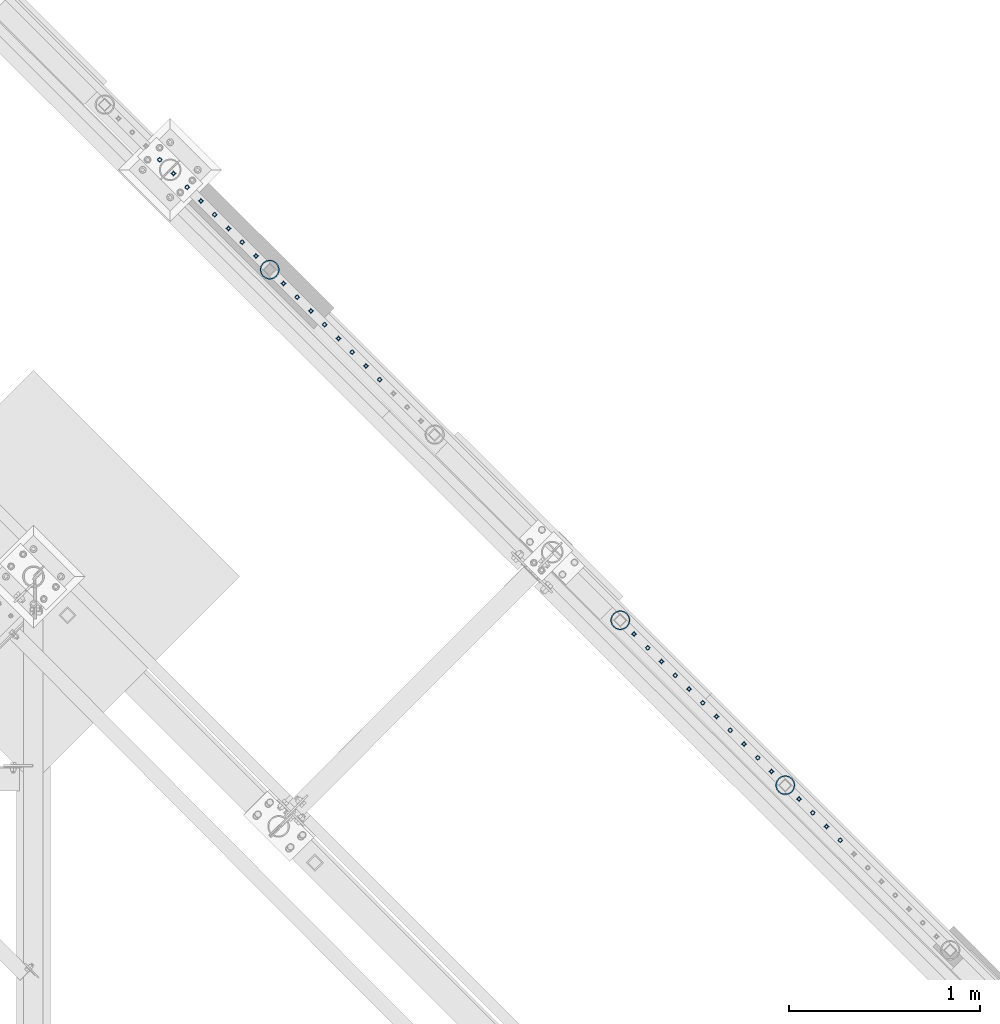
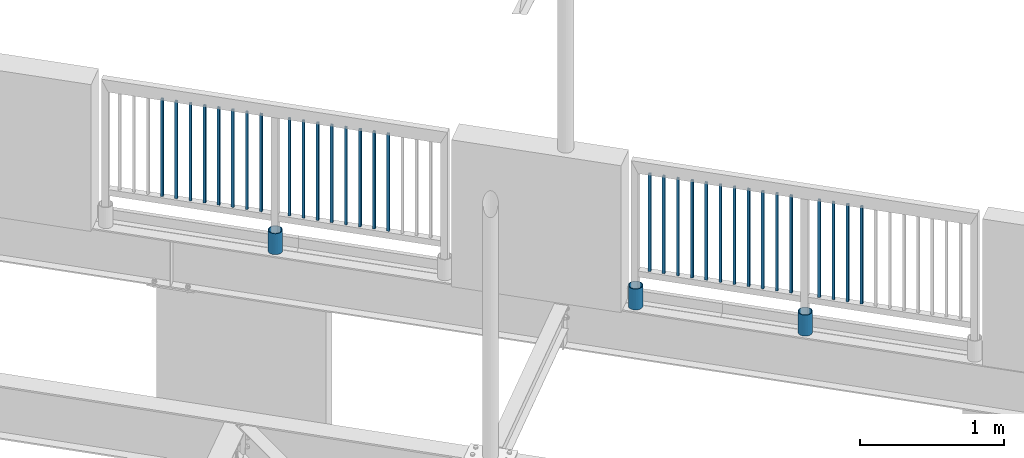
# One storey, part 282 of 975: 34 columns.
"""IFC2X3 building model written with IfcOpenShell, lengths in millimetres."""

from ifc_helpers import new_model, si_unit, frame, origin_with_axes, place, context, subcontext, project, spatial, faceted_brep, material, type_object, element, save


model = new_model("IFC2X3")

# Units and contexts
model_context = context("Model", 3, precision=1e-05, world=origin_with_axes())
body_context = subcontext(model_context, "Body", "Model", "MODEL_VIEW")
ifc_project = project(units=[si_unit("LENGTHUNIT", "METRE", prefix="MILLI"), si_unit("AREAUNIT", "SQUARE_METRE"), si_unit("VOLUMEUNIT", "CUBIC_METRE"), si_unit("MASSUNIT", "GRAM", prefix="KILO"), si_unit("TIMEUNIT", "SECOND"), si_unit("PLANEANGLEUNIT", "RADIAN"), si_unit("SOLIDANGLEUNIT", "STERADIAN"), si_unit("THERMODYNAMICTEMPERATUREUNIT", "DEGREE_CELSIUS"), si_unit("LUMINOUSINTENSITYUNIT", "LUMEN")], contexts=[model_context])

# Site, building, storey
site_placement = place(None, origin_with_axes())
site = spatial("IfcSite", under=ifc_project, at=site_placement, CompositionType="ELEMENT")
building_placement = place(site_placement, origin_with_axes())
building = spatial("IfcBuilding", under=site, at=building_placement, Name="Undefined", CompositionType="ELEMENT")
storey_placement = place(building_placement, origin_with_axes())
storey = spatial("IfcBuildingStorey", under=building, at=storey_placement, Name="Undefined", CompositionType="ELEMENT", Elevation=0.0)

# Columns
ifc_material_1 = material()
column_type_1 = type_object("IfcColumnType", Name="HSS3/4X3/4X.120_TUBES", PredefinedType="NOTDEFINED")
for number, where, z_axis, x_axis, name in (
    (1, (30492.0120228262, 18142.420418701, 4254.499875366), (-0.707106781186601, 0.707106781186494, 2.36468622460961e-14), (0.0, 0.0, 1.0), "PICKET"),
    (2, (30563.8463978262, 18070.586043701, 4254.499875366), (-0.707106781186601, 0.707106781186494, 2.36468622460961e-14), (0.0, 0.0, 1.0), "PICKET"),
    (3, (30635.6807728262, 17998.751668701, 4254.499875366), (-0.707106781186601, 0.707106781186494, 2.36468622460961e-14), (0.0, 0.0, 1.0), "PICKET"),
    (4, (30707.5151478262, 17926.917293701, 4254.499875366), (-0.707106781186601, 0.707106781186494, 2.36468622460961e-14), (0.0, 0.0, 1.0), "PICKET"),
    (5, (30779.3495228262, 17855.082918701, 4254.499875366), (-0.707106781186601, 0.707106781186494, 2.36468622460961e-14), (0.0, 0.0, 1.0), "PICKET"),
    (6, (30851.1838978262, 17783.248543701, 4254.499875366), (-0.707106781186601, 0.707106781186494, 2.36468622460961e-14), (0.0, 0.0, 1.0), "PICKET"),
    (7, (30923.0182728262, 17711.414168701, 4254.499875366), (-0.707106781186601, 0.707106781186494, 2.36468622460961e-14), (0.0, 0.0, 1.0), "PICKET"),
    (8, (30994.8526478262, 17639.579793701, 4254.499875366), (-0.707106781186601, 0.707106781186494, 2.36468622460961e-14), (0.0, 0.0, 1.0), "PICKET"),
    (9, (31138.6102441323, 17495.808183989, 4254.49994796676), (-0.707106781186601, 0.707106781186494, 2.36468622460961e-14), (0.0, 0.0, 1.0), "PICKET"),
    (10, (31210.4446191323, 17423.973808989, 4254.49994796676), (-0.707106781186601, 0.707106781186494, 2.36468622460961e-14), (0.0, 0.0, 1.0), "PICKET"),
    (11, (31282.2789941323, 17352.139433989, 4254.49994796676), (-0.707106781186601, 0.707106781186494, 2.36468622460961e-14), (0.0, 0.0, 1.0), "PICKET"),
    (12, (31354.1133691323, 17280.305058989, 4254.49994796676), (-0.707106781186601, 0.707106781186494, 2.36468622460961e-14), (0.0, 0.0, 1.0), "PICKET"),
    (13, (31425.9477441323, 17208.470683989, 4254.49994796676), (-0.707106781186601, 0.707106781186494, 2.36468622460961e-14), (0.0, 0.0, 1.0), "PICKET"),
    (14, (31497.7821191323, 17136.636308989, 4254.49994796676), (-0.707106781186601, 0.707106781186494, 2.36468622460961e-14), (0.0, 0.0, 1.0), "PICKET"),
    (15, (31569.6164941323, 17064.801933989, 4254.49994796676), (-0.707106781186601, 0.707106781186494, 2.36468622460961e-14), (0.0, 0.0, 1.0), "PICKET"),
    (16, (31641.4508691323, 16992.967558989, 4254.49994796676), (-0.707106781186601, 0.707106781186494, 2.36468622460961e-14), (0.0, 0.0, 1.0), "PICKET"),
    (17, (32970.5284701744, 15663.7814073619, 4254.49987536521), (-0.707106781186601, 0.707106781186494, 2.36468622460961e-14), (0.0, 0.0, 1.0), "PICKET"),
    (18, (33042.3628451744, 15591.9470323619, 4254.49987536521), (-0.707106781186601, 0.707106781186494, 2.36468622460961e-14), (0.0, 0.0, 1.0), "PICKET"),
    (19, (33114.1972201744, 15520.1126573619, 4254.49987536521), (-0.707106781186601, 0.707106781186494, 2.36468622460961e-14), (0.0, 0.0, 1.0), "PICKET"),
    (20, (33186.0315951744, 15448.2782823619, 4254.49987536521), (-0.707106781186601, 0.707106781186494, 2.36468622460961e-14), (0.0, 0.0, 1.0), "PICKET"),
    (21, (33257.8659701744, 15376.4439073619, 4254.49987536521), (-0.707106781186601, 0.707106781186494, 2.36468622460961e-14), (0.0, 0.0, 1.0), "PICKET"),
    (22, (33329.7003451744, 15304.6095323619, 4254.49987536521), (-0.707106781186601, 0.707106781186494, 2.36468622460961e-14), (0.0, 0.0, 1.0), "PICKET"),
    (23, (33401.5347201744, 15232.7751573619, 4254.49987536521), (-0.707106781186601, 0.707106781186494, 2.36468622460961e-14), (0.0, 0.0, 1.0), "PICKET"),
    (24, (33473.3690951744, 15160.9407823619, 4254.49987536521), (-0.707106781186601, 0.707106781186494, 2.36468622460961e-14), (0.0, 0.0, 1.0), "PICKET"),
    (25, (33545.2034701744, 15089.1064073619, 4254.49987536521), (-0.707106781186601, 0.707106781186494, 2.36468622460961e-14), (0.0, 0.0, 1.0), "PICKET"),
    (26, (33617.0378451744, 15017.2720323619, 4254.49987536521), (-0.707106781186601, 0.707106781186494, 2.36468622460961e-14), (0.0, 0.0, 1.0), "PICKET"),
    (27, (33688.8722201744, 14945.4376573619, 4254.49987536521), (-0.707106781186601, 0.707106781186494, 2.36468622460961e-14), (0.0, 0.0, 1.0), "PICKET"),
    (28, (33832.6298164805, 14801.6660476498, 4254.49994796637), (-0.707106781186601, 0.707106781186494, 2.36468622460961e-14), (0.0, 0.0, 1.0), "PICKET"),
    (29, (33904.4641914805, 14729.8316726498, 4254.49994796637), (-0.707106781186601, 0.707106781186494, 2.36468622460961e-14), (0.0, 0.0, 1.0), "PICKET"),
    (30, (33976.2985664805, 14657.9972976498, 4254.49994796637), (-0.707106781186601, 0.707106781186494, 2.36468622460961e-14), (0.0, 0.0, 1.0), "PICKET"),
    (31, (34048.1329414805, 14586.1629226498, 4254.49994796637), (-0.707106781186601, 0.707106781186494, 2.36468622460961e-14), (0.0, 0.0, 1.0), "PICKET"),
):
    element("IfcColumn", number, at=place(storey_placement, frame(where, z_axis=z_axis, x_axis=x_axis)), inside=storey, type_object=column_type_1, material=ifc_material_1, Name=name, ObjectType="HSS3/4X3/4X.120_TUBES", context=body_context, shape_type="Brep", body=[
        faceted_brep([(0.0, 6.34999999998763, -6.34999999998763), (0.0, -6.35000000000582, -6.34999999998763), (825.49997943247, -6.35000000000582, -6.34999999998763), (825.49997943247, 6.34999999998763, -6.34999999998763), (0.0, -6.34999999998763, 6.34999999998763), (825.49997943247, -6.34999999998763, 6.34999999998763), (0.0, 6.35000000000946, 6.34999999998763), (825.49997943247, 6.35000000000946, 6.34999999998763), (0.0, 9.52499999997963, -9.52499999997963), (0.0, 9.52500000000873, 9.5249999999869), (825.49997943247, 9.52500000000873, 9.5249999999869), (825.49997943247, 9.52499999997963, -9.52499999997963), (0.0, -9.52499999997963, 9.52499999998327), (825.49997943247, -9.52499999997963, 9.52499999998327), (0.0, -9.52500000000873, -9.5249999999869), (825.49997943247, -9.52500000000873, -9.5249999999869)], [[[0, 1, 2, 3]], [[1, 4, 5, 2]], [[4, 6, 7, 5]], [[6, 0, 3, 7]], [[8, 9, 10, 11]], [[9, 12, 13, 10]], [[12, 14, 15, 13]], [[14, 8, 11, 15]], [[13, 15, 11, 10], [5, 7, 3, 2]], [[14, 12, 9, 8], [6, 4, 1, 0]]]),
    ])
ifc_material_2 = material(Name="STEEL/A53")
column_type_2 = type_object("IfcColumnType", Name="PIPE3-1/2STD", PredefinedType="NOTDEFINED")
column_1_placement = place(storey_placement, frame((33760.9334726132, 14873.8955711457, 3937.0), z_axis=(-0.707106781186601, 0.707106781186494, 2.36468622460961e-14), x_axis=(0.0, 0.0, 1.0)))
element("IfcColumn", 32, at=column_1_placement, inside=storey, type_object=column_type_2, material=ifc_material_2, ObjectType="PIPE3-1/2STD", context=body_context, shape_type="Brep", body=[
    faceted_brep([(0.0, -45.0595999999932, 1.45519152283669e-11), (0.0, -42.8542262016344, 13.924182159768), (177.8, -42.8542262016344, 13.924182159768), (177.8, -45.0595999999932, 1.45519152283669e-11), (0.0, -36.45398215971, 26.4853683542424), (177.8, -36.45398215971, 26.4853683542424), (0.0, -26.4853683541623, 36.45398215979), (177.8, -26.4853683541623, 36.45398215979), (0.0, -13.9241821596988, 42.8542262017108), (177.8, -13.9241821596988, 42.8542262017108), (0.0, 3.63797880709171e-11, 45.0596000000514), (177.8, 3.63797880709171e-11, 45.0596000000514), (0.0, 13.9241821597716, 42.8542262017036), (177.8, 13.9241821597716, 42.8542262017036), (0.0, 26.4853683542242, 36.4539821597718), (177.8, 26.4853683542242, 36.4539821597718), (0.0, 36.4539821597537, 26.4853683542206), (177.8, 36.4539821597537, 26.4853683542206), (0.0, 42.8542262016563, 13.9241821597425), (177.8, 42.8542262016563, 13.9241821597425), (0.0, 45.0595999999932, -1.09139364212751e-11), (177.8, 45.0595999999932, -1.09139364212751e-11), (0.0, 42.8542262016344, -13.9241821597643), (177.8, 42.8542262016344, -13.9241821597643), (0.0, 36.45398215971, -26.4853683542387), (177.8, 36.45398215971, -26.4853683542387), (0.0, 26.4853683541623, -36.4539821597864), (177.8, 26.4853683541623, -36.4539821597864), (0.0, 13.9241821596988, -42.8542262017072), (177.8, 13.9241821596988, -42.8542262017072), (0.0, -3.63797880709171e-11, -45.0596000000478), (177.8, -3.63797880709171e-11, -45.0596000000478), (0.0, -13.9241821597716, -42.8542262016963), (177.8, -13.9241821597716, -42.8542262016963), (0.0, -26.4853683542242, -36.4539821597682), (177.8, -26.4853683542242, -36.4539821597682), (0.0, -36.4539821597537, -26.4853683542169), (177.8, -36.4539821597537, -26.4853683542169), (0.0, -42.8542262016563, -13.9241821597352), (177.8, -42.8542262016563, -13.9241821597352), (0.0, -50.799999999992, 1.81898940354586e-11), (0.0, -48.3136710278013, -15.6980633142484), (177.8, -48.3136710278013, -15.6980633142484), (177.8, -50.799999999992, 1.81898940354586e-11), (0.0, -41.0980633142644, -29.8594908164741), (177.8, -41.0980633142644, -29.8594908164741), (0.0, -29.859490816485, -41.0980633142826), (177.8, -29.859490816485, -41.0980633142826), (0.0, -15.6980633142848, -48.313671027845), (177.8, -15.6980633142848, -48.313671027845), (0.0, -4.36557456851006e-11, -50.8000000000575), (177.8, -4.36557456851006e-11, -50.8000000000575), (0.0, 15.6980633142011, -48.3136710278523), (177.8, 15.6980633142011, -48.3136710278523), (0.0, 29.8594908164159, -41.0980633143045), (177.8, 29.8594908164159, -41.0980633143045), (0.0, 41.0980633142135, -29.8594908165032), (177.8, 41.0980633142135, -29.8594908165032), (0.0, 48.3136710277722, -15.6980633142775), (177.8, 48.3136710277722, -15.6980633142775), (0.0, 50.799999999992, -1.45519152283669e-11), (177.8, 50.799999999992, -1.45519152283669e-11), (0.0, 48.313671027794, 15.6980633142521), (177.8, 48.313671027794, 15.6980633142521), (0.0, 41.0980633142644, 29.8594908164814), (177.8, 41.0980633142644, 29.8594908164814), (0.0, 29.859490816485, 41.0980633142863), (177.8, 29.859490816485, 41.0980633142863), (0.0, 15.6980633142848, 48.3136710278486), (177.8, 15.6980633142848, 48.3136710278486), (0.0, 4.00177668780088e-11, 50.8000000000611), (177.8, 4.00177668780088e-11, 50.8000000000611), (0.0, -15.6980633142011, 48.3136710278559), (177.8, -15.6980633142011, 48.3136710278559), (0.0, -29.8594908164159, 41.0980633143081), (177.8, -29.8594908164159, 41.0980633143081), (0.0, -41.0980633142171, 29.8594908165069), (177.8, -41.0980633142171, 29.8594908165069), (0.0, -48.3136710277722, 15.6980633142812), (177.8, -48.3136710277722, 15.6980633142812)], [[[0, 1, 2, 3]], [[1, 4, 5, 2]], [[4, 6, 7, 5]], [[6, 8, 9, 7]], [[8, 10, 11, 9]], [[10, 12, 13, 11]], [[12, 14, 15, 13]], [[14, 16, 17, 15]], [[16, 18, 19, 17]], [[18, 20, 21, 19]], [[20, 22, 23, 21]], [[22, 24, 25, 23]], [[24, 26, 27, 25]], [[26, 28, 29, 27]], [[28, 30, 31, 29]], [[30, 32, 33, 31]], [[32, 34, 35, 33]], [[34, 36, 37, 35]], [[36, 38, 39, 37]], [[38, 0, 3, 39]], [[40, 41, 42, 43]], [[41, 44, 45, 42]], [[44, 46, 47, 45]], [[46, 48, 49, 47]], [[48, 50, 51, 49]], [[50, 52, 53, 51]], [[52, 54, 55, 53]], [[54, 56, 57, 55]], [[56, 58, 59, 57]], [[58, 60, 61, 59]], [[60, 62, 63, 61]], [[62, 64, 65, 63]], [[64, 66, 67, 65]], [[66, 68, 69, 67]], [[68, 70, 71, 69]], [[70, 72, 73, 71]], [[72, 74, 75, 73]], [[74, 76, 77, 75]], [[76, 78, 79, 77]], [[78, 40, 43, 79]], [[45, 47, 49, 51, 53, 55, 57, 59, 61, 63, 65, 67, 69, 71, 73, 75, 77, 79, 43, 42], [5, 7, 9, 11, 13, 15, 17, 19, 21, 23, 25, 27, 29, 31, 33, 35, 37, 39, 3, 2]], [[78, 76, 74, 72, 70, 68, 66, 64, 62, 60, 58, 56, 54, 52, 50, 48, 46, 44, 41, 40], [38, 36, 34, 32, 30, 28, 26, 24, 22, 20, 18, 16, 14, 12, 10, 8, 6, 4, 1, 0]]]),
])
column_2_placement = place(storey_placement, frame((31066.8280697486, 17567.7896527212, 3937.0), z_axis=(-0.707106781186601, 0.707106781186494, 2.36468622460961e-14), x_axis=(0.0, 0.0, 1.0)))
element("IfcColumn", 33, at=column_2_placement, inside=storey, type_object=column_type_2, material=ifc_material_2, ObjectType="PIPE3-1/2STD", context=body_context, shape_type="Brep", body=[
    faceted_brep([(0.0, -45.0595999999932, 1.45519152283669e-11), (0.0, -42.8542262016344, 13.924182159768), (177.8, -42.8542262016344, 13.924182159768), (177.8, -45.0595999999932, 1.45519152283669e-11), (0.0, -36.45398215971, 26.4853683542424), (177.8, -36.45398215971, 26.4853683542424), (0.0, -26.4853683541623, 36.45398215979), (177.8, -26.4853683541623, 36.45398215979), (0.0, -13.9241821596988, 42.8542262017108), (177.8, -13.9241821596988, 42.8542262017108), (0.0, 3.63797880709171e-11, 45.0596000000514), (177.8, 3.63797880709171e-11, 45.0596000000514), (0.0, 13.9241821597716, 42.8542262017036), (177.8, 13.9241821597716, 42.8542262017036), (0.0, 26.4853683542242, 36.4539821597718), (177.8, 26.4853683542242, 36.4539821597718), (0.0, 36.4539821597537, 26.4853683542206), (177.8, 36.4539821597537, 26.4853683542206), (0.0, 42.8542262016563, 13.9241821597425), (177.8, 42.8542262016563, 13.9241821597425), (0.0, 45.0595999999932, -1.09139364212751e-11), (177.8, 45.0595999999932, -1.09139364212751e-11), (0.0, 42.8542262016344, -13.9241821597643), (177.8, 42.8542262016344, -13.9241821597643), (0.0, 36.45398215971, -26.4853683542387), (177.8, 36.45398215971, -26.4853683542387), (0.0, 26.4853683541623, -36.4539821597864), (177.8, 26.4853683541623, -36.4539821597864), (0.0, 13.9241821596988, -42.8542262017072), (177.8, 13.9241821596988, -42.8542262017072), (0.0, -3.63797880709171e-11, -45.0596000000478), (177.8, -3.63797880709171e-11, -45.0596000000478), (0.0, -13.9241821597716, -42.8542262016963), (177.8, -13.9241821597716, -42.8542262016963), (0.0, -26.4853683542242, -36.4539821597682), (177.8, -26.4853683542242, -36.4539821597682), (0.0, -36.4539821597537, -26.4853683542169), (177.8, -36.4539821597537, -26.4853683542169), (0.0, -42.8542262016563, -13.9241821597352), (177.8, -42.8542262016563, -13.9241821597352), (0.0, -50.799999999992, 1.81898940354586e-11), (0.0, -48.3136710278013, -15.6980633142484), (177.8, -48.3136710278013, -15.6980633142484), (177.8, -50.799999999992, 1.81898940354586e-11), (0.0, -41.0980633142644, -29.8594908164741), (177.8, -41.0980633142644, -29.8594908164741), (0.0, -29.859490816485, -41.0980633142826), (177.8, -29.859490816485, -41.0980633142826), (0.0, -15.6980633142848, -48.313671027845), (177.8, -15.6980633142848, -48.313671027845), (0.0, -4.36557456851006e-11, -50.8000000000575), (177.8, -4.36557456851006e-11, -50.8000000000575), (0.0, 15.6980633142011, -48.3136710278523), (177.8, 15.6980633142011, -48.3136710278523), (0.0, 29.8594908164159, -41.0980633143045), (177.8, 29.8594908164159, -41.0980633143045), (0.0, 41.0980633142135, -29.8594908165032), (177.8, 41.0980633142135, -29.8594908165032), (0.0, 48.3136710277722, -15.6980633142775), (177.8, 48.3136710277722, -15.6980633142775), (0.0, 50.799999999992, -1.45519152283669e-11), (177.8, 50.799999999992, -1.45519152283669e-11), (0.0, 48.313671027794, 15.6980633142521), (177.8, 48.313671027794, 15.6980633142521), (0.0, 41.0980633142644, 29.8594908164814), (177.8, 41.0980633142644, 29.8594908164814), (0.0, 29.859490816485, 41.0980633142863), (177.8, 29.859490816485, 41.0980633142863), (0.0, 15.6980633142848, 48.3136710278486), (177.8, 15.6980633142848, 48.3136710278486), (0.0, 4.00177668780088e-11, 50.8000000000611), (177.8, 4.00177668780088e-11, 50.8000000000611), (0.0, -15.6980633142011, 48.3136710278559), (177.8, -15.6980633142011, 48.3136710278559), (0.0, -29.8594908164159, 41.0980633143081), (177.8, -29.8594908164159, 41.0980633143081), (0.0, -41.0980633142171, 29.8594908165069), (177.8, -41.0980633142171, 29.8594908165069), (0.0, -48.3136710277722, 15.6980633142812), (177.8, -48.3136710277722, 15.6980633142812)], [[[0, 1, 2, 3]], [[1, 4, 5, 2]], [[4, 6, 7, 5]], [[6, 8, 9, 7]], [[8, 10, 11, 9]], [[10, 12, 13, 11]], [[12, 14, 15, 13]], [[14, 16, 17, 15]], [[16, 18, 19, 17]], [[18, 20, 21, 19]], [[20, 22, 23, 21]], [[22, 24, 25, 23]], [[24, 26, 27, 25]], [[26, 28, 29, 27]], [[28, 30, 31, 29]], [[30, 32, 33, 31]], [[32, 34, 35, 33]], [[34, 36, 37, 35]], [[36, 38, 39, 37]], [[38, 0, 3, 39]], [[40, 41, 42, 43]], [[41, 44, 45, 42]], [[44, 46, 47, 45]], [[46, 48, 49, 47]], [[48, 50, 51, 49]], [[50, 52, 53, 51]], [[52, 54, 55, 53]], [[54, 56, 57, 55]], [[56, 58, 59, 57]], [[58, 60, 61, 59]], [[60, 62, 63, 61]], [[62, 64, 65, 63]], [[64, 66, 67, 65]], [[66, 68, 69, 67]], [[68, 70, 71, 69]], [[70, 72, 73, 71]], [[72, 74, 75, 73]], [[74, 76, 77, 75]], [[76, 78, 79, 77]], [[78, 40, 43, 79]], [[45, 47, 49, 51, 53, 55, 57, 59, 61, 63, 65, 67, 69, 71, 73, 75, 77, 79, 43, 42], [5, 7, 9, 11, 13, 15, 17, 19, 21, 23, 25, 27, 29, 31, 33, 35, 37, 39, 3, 2]], [[78, 76, 74, 72, 70, 68, 66, 64, 62, 60, 58, 56, 54, 52, 50, 48, 46, 44, 41, 40], [38, 36, 34, 32, 30, 28, 26, 24, 22, 20, 18, 16, 14, 12, 10, 8, 6, 4, 1, 0]]]),
])
column_3_placement = place(storey_placement, frame((32898.8240007501, 15736.0046147149, 3937.0), z_axis=(-0.707106781186601, 0.707106781186494, 2.36468622460961e-14), x_axis=(0.0, 0.0, 1.0)))
element("IfcColumn", 34, at=column_3_placement, inside=storey, type_object=column_type_2, material=ifc_material_2, ObjectType="PIPE3-1/2STD", context=body_context, shape_type="Brep", body=[
    faceted_brep([(0.0, -45.0595999999932, 1.45519152283669e-11), (0.0, -42.8542262016344, 13.924182159768), (177.8, -42.8542262016344, 13.924182159768), (177.8, -45.0595999999932, 1.45519152283669e-11), (0.0, -36.45398215971, 26.4853683542424), (177.8, -36.45398215971, 26.4853683542424), (0.0, -26.4853683541623, 36.45398215979), (177.8, -26.4853683541623, 36.45398215979), (0.0, -13.9241821596988, 42.8542262017108), (177.8, -13.9241821596988, 42.8542262017108), (0.0, 3.63797880709171e-11, 45.0596000000514), (177.8, 3.63797880709171e-11, 45.0596000000514), (0.0, 13.9241821597716, 42.8542262017036), (177.8, 13.9241821597716, 42.8542262017036), (0.0, 26.4853683542242, 36.4539821597718), (177.8, 26.4853683542242, 36.4539821597718), (0.0, 36.4539821597537, 26.4853683542206), (177.8, 36.4539821597537, 26.4853683542206), (0.0, 42.8542262016563, 13.9241821597425), (177.8, 42.8542262016563, 13.9241821597425), (0.0, 45.0595999999932, -1.09139364212751e-11), (177.8, 45.0595999999932, -1.09139364212751e-11), (0.0, 42.8542262016344, -13.9241821597643), (177.8, 42.8542262016344, -13.9241821597643), (0.0, 36.45398215971, -26.4853683542387), (177.8, 36.45398215971, -26.4853683542387), (0.0, 26.4853683541623, -36.4539821597864), (177.8, 26.4853683541623, -36.4539821597864), (0.0, 13.9241821596988, -42.8542262017072), (177.8, 13.9241821596988, -42.8542262017072), (0.0, -3.63797880709171e-11, -45.0596000000478), (177.8, -3.63797880709171e-11, -45.0596000000478), (0.0, -13.9241821597716, -42.8542262016963), (177.8, -13.9241821597716, -42.8542262016963), (0.0, -26.4853683542242, -36.4539821597682), (177.8, -26.4853683542242, -36.4539821597682), (0.0, -36.4539821597537, -26.4853683542169), (177.8, -36.4539821597537, -26.4853683542169), (0.0, -42.8542262016563, -13.9241821597352), (177.8, -42.8542262016563, -13.9241821597352), (0.0, -50.799999999992, 1.81898940354586e-11), (0.0, -48.3136710278013, -15.6980633142484), (177.8, -48.3136710278013, -15.6980633142484), (177.8, -50.799999999992, 1.81898940354586e-11), (0.0, -41.0980633142644, -29.8594908164741), (177.8, -41.0980633142644, -29.8594908164741), (0.0, -29.859490816485, -41.0980633142826), (177.8, -29.859490816485, -41.0980633142826), (0.0, -15.6980633142848, -48.313671027845), (177.8, -15.6980633142848, -48.313671027845), (0.0, -4.36557456851006e-11, -50.8000000000575), (177.8, -4.36557456851006e-11, -50.8000000000575), (0.0, 15.6980633142011, -48.3136710278523), (177.8, 15.6980633142011, -48.3136710278523), (0.0, 29.8594908164159, -41.0980633143045), (177.8, 29.8594908164159, -41.0980633143045), (0.0, 41.0980633142135, -29.8594908165032), (177.8, 41.0980633142135, -29.8594908165032), (0.0, 48.3136710277722, -15.6980633142775), (177.8, 48.3136710277722, -15.6980633142775), (0.0, 50.799999999992, -1.45519152283669e-11), (177.8, 50.799999999992, -1.45519152283669e-11), (0.0, 48.313671027794, 15.6980633142521), (177.8, 48.313671027794, 15.6980633142521), (0.0, 41.0980633142644, 29.8594908164814), (177.8, 41.0980633142644, 29.8594908164814), (0.0, 29.859490816485, 41.0980633142863), (177.8, 29.859490816485, 41.0980633142863), (0.0, 15.6980633142848, 48.3136710278486), (177.8, 15.6980633142848, 48.3136710278486), (0.0, 4.00177668780088e-11, 50.8000000000611), (177.8, 4.00177668780088e-11, 50.8000000000611), (0.0, -15.6980633142011, 48.3136710278559), (177.8, -15.6980633142011, 48.3136710278559), (0.0, -29.8594908164159, 41.0980633143081), (177.8, -29.8594908164159, 41.0980633143081), (0.0, -41.0980633142171, 29.8594908165069), (177.8, -41.0980633142171, 29.8594908165069), (0.0, -48.3136710277722, 15.6980633142812), (177.8, -48.3136710277722, 15.6980633142812)], [[[0, 1, 2, 3]], [[1, 4, 5, 2]], [[4, 6, 7, 5]], [[6, 8, 9, 7]], [[8, 10, 11, 9]], [[10, 12, 13, 11]], [[12, 14, 15, 13]], [[14, 16, 17, 15]], [[16, 18, 19, 17]], [[18, 20, 21, 19]], [[20, 22, 23, 21]], [[22, 24, 25, 23]], [[24, 26, 27, 25]], [[26, 28, 29, 27]], [[28, 30, 31, 29]], [[30, 32, 33, 31]], [[32, 34, 35, 33]], [[34, 36, 37, 35]], [[36, 38, 39, 37]], [[38, 0, 3, 39]], [[40, 41, 42, 43]], [[41, 44, 45, 42]], [[44, 46, 47, 45]], [[46, 48, 49, 47]], [[48, 50, 51, 49]], [[50, 52, 53, 51]], [[52, 54, 55, 53]], [[54, 56, 57, 55]], [[56, 58, 59, 57]], [[58, 60, 61, 59]], [[60, 62, 63, 61]], [[62, 64, 65, 63]], [[64, 66, 67, 65]], [[66, 68, 69, 67]], [[68, 70, 71, 69]], [[70, 72, 73, 71]], [[72, 74, 75, 73]], [[74, 76, 77, 75]], [[76, 78, 79, 77]], [[78, 40, 43, 79]], [[45, 47, 49, 51, 53, 55, 57, 59, 61, 63, 65, 67, 69, 71, 73, 75, 77, 79, 43, 42], [5, 7, 9, 11, 13, 15, 17, 19, 21, 23, 25, 27, 29, 31, 33, 35, 37, 39, 3, 2]], [[78, 76, 74, 72, 70, 68, 66, 64, 62, 60, 58, 56, 54, 52, 50, 48, 46, 44, 41, 40], [38, 36, 34, 32, 30, 28, 26, 24, 22, 20, 18, 16, 14, 12, 10, 8, 6, 4, 1, 0]]]),
])

save(model, "model.ifc")
